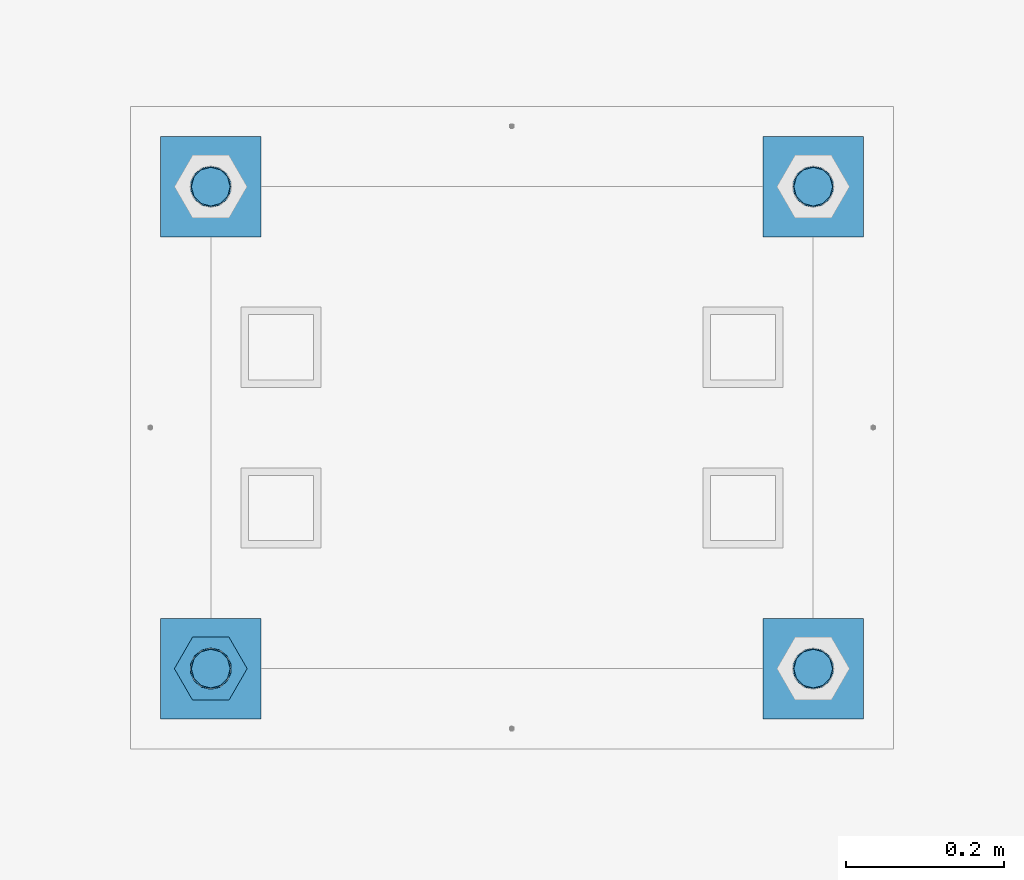
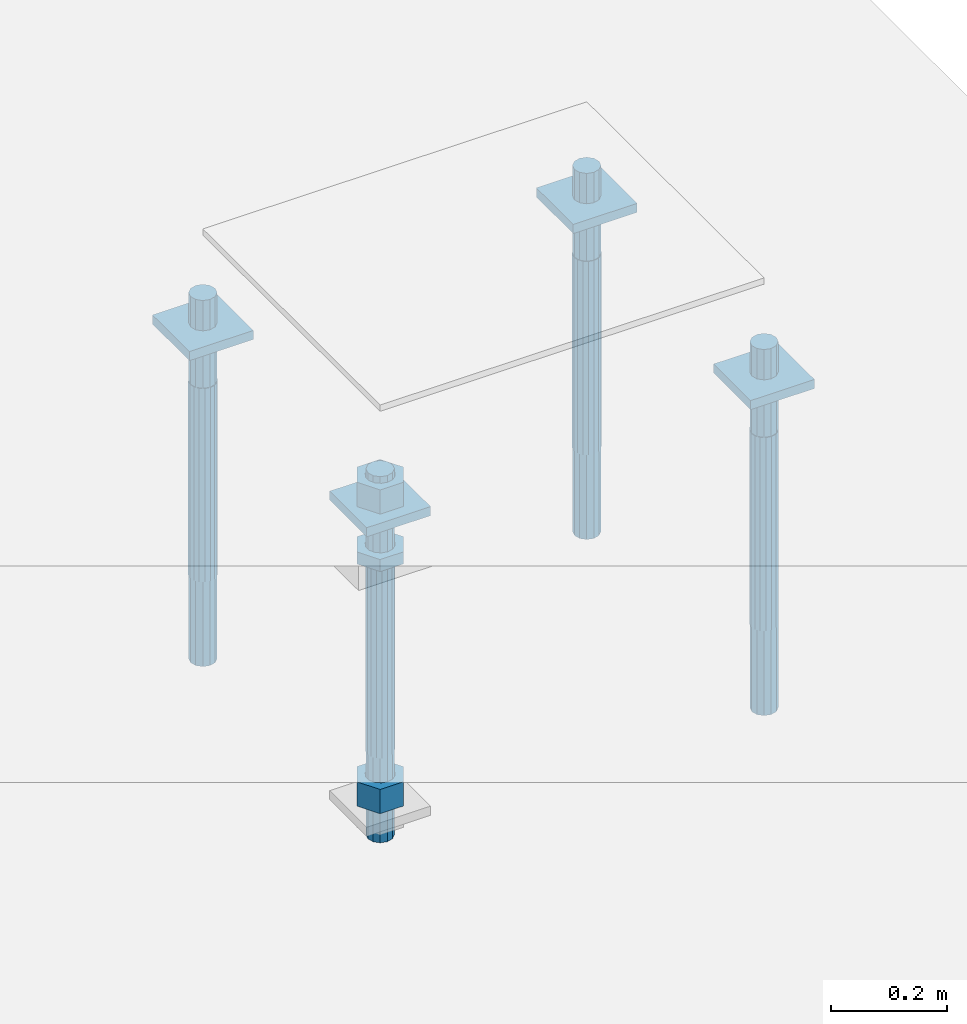
# One storey, part 2680 of 3843: 11 beams, 1 element without a shape of its own.
"""IFC2X3 building model written with IfcOpenShell, lengths in millimetres."""

from ifc_helpers import new_model, si_unit, frame, origin_with_axes, place, context, subcontext, project, spatial, faceted_brep, material, type_object, element, aggregate, save


model = new_model("IFC2X3")

# Units and contexts
model_context = context("Model", 3, precision=1e-05, world=origin_with_axes())
body_context = subcontext(model_context, "Body", "Model", "MODEL_VIEW")
ifc_project = project(units=[si_unit("LENGTHUNIT", "METRE", prefix="MILLI"), si_unit("AREAUNIT", "SQUARE_METRE"), si_unit("VOLUMEUNIT", "CUBIC_METRE"), si_unit("MASSUNIT", "GRAM", prefix="KILO"), si_unit("TIMEUNIT", "SECOND"), si_unit("PLANEANGLEUNIT", "RADIAN"), si_unit("SOLIDANGLEUNIT", "STERADIAN"), si_unit("THERMODYNAMICTEMPERATUREUNIT", "DEGREE_CELSIUS"), si_unit("LUMINOUSINTENSITYUNIT", "LUMEN")], contexts=[model_context])

# Site, building, storey
site_placement = place(None, origin_with_axes())
site = spatial("IfcSite", under=ifc_project, at=site_placement, CompositionType="ELEMENT")
building_placement = place(site_placement, origin_with_axes())
building = spatial("IfcBuilding", under=site, at=building_placement, Name="Undefined", CompositionType="ELEMENT")
storey_placement = place(building_placement, origin_with_axes())
storey = spatial("IfcBuildingStorey", under=building, at=storey_placement, Name="Undefined", CompositionType="ELEMENT", Elevation=0.0)

# Assembly, beams
assembly_placement = place(storey_placement, origin_with_axes())
assembly = element("IfcElementAssembly", 1, at=assembly_placement, inside=storey, Name="TEMPLATE", AssemblyPlace="NOTDEFINED", PredefinedType="RIGID_FRAME")
ifc_material_1 = material(Name="STEEL/A572-50")
beam_type_1 = type_object("IfcBeamType", PredefinedType="NOTDEFINED")
beam_1_placement = place(assembly_placement, frame((118465.6, 29044.9000015259, 29873.575), z_axis=(1.0, 0.0, 0.0), x_axis=(0.0, 1.0, 0.0)))
beam_1 = element("IfcBeam", 2, at=beam_1_placement, type_object=beam_type_1, material=ifc_material_1, Name="WASHER_PLATE", context=body_context, shape_type="Brep", body=[
    faceted_brep([(0.0, 9.52500000000146, -63.5), (0.0, 9.52500000000146, 63.5), (127.0, 9.52500000000146, 63.5), (127.0, 9.52500000000146, -63.5), (0.0, -9.52500000000146, 63.5), (127.0, -9.52500000000146, 63.5), (0.0, -9.52500000000146, -63.5), (127.0, -9.52500000000146, -63.5)], [[[0, 1, 2, 3]], [[1, 4, 5, 2]], [[4, 6, 7, 5]], [[6, 0, 3, 7]], [[5, 7, 3, 2]], [[6, 4, 1, 0]]]),
])
beam_2_placement = place(assembly_placement, frame((119227.6, 29044.9000015259, 29873.575), z_axis=(1.0, 0.0, 0.0), x_axis=(0.0, 1.0, 0.0)))
beam_2 = element("IfcBeam", 3, at=beam_2_placement, type_object=beam_type_1, material=ifc_material_1, Name="WASHER_PLATE", context=body_context, shape_type="Brep", body=[
    faceted_brep([(0.0, 9.52500000000146, -63.5), (0.0, 9.52500000000146, 63.5), (127.0, 9.52500000000146, 63.5), (127.0, 9.52500000000146, -63.5), (0.0, -9.52500000000146, 63.5), (127.0, -9.52500000000146, 63.5), (0.0, -9.52500000000146, -63.5), (127.0, -9.52500000000146, -63.5)], [[[0, 1, 2, 3]], [[1, 4, 5, 2]], [[4, 6, 7, 5]], [[6, 0, 3, 7]], [[5, 7, 3, 2]], [[6, 4, 1, 0]]]),
])
beam_3_placement = place(assembly_placement, frame((118465.6, 29654.5000015259, 29873.575), z_axis=(1.0, 0.0, 0.0), x_axis=(0.0, 1.0, 0.0)))
beam_3 = element("IfcBeam", 4, at=beam_3_placement, type_object=beam_type_1, material=ifc_material_1, Name="WASHER_PLATE", context=body_context, shape_type="Brep", body=[
    faceted_brep([(0.0, 9.52500000000146, -63.5), (0.0, 9.52500000000146, 63.5), (127.0, 9.52500000000146, 63.5), (127.0, 9.52500000000146, -63.5), (0.0, -9.52500000000146, 63.5), (127.0, -9.52500000000146, 63.5), (0.0, -9.52500000000146, -63.5), (127.0, -9.52500000000146, -63.5)], [[[0, 1, 2, 3]], [[1, 4, 5, 2]], [[4, 6, 7, 5]], [[6, 0, 3, 7]], [[5, 7, 3, 2]], [[6, 4, 1, 0]]]),
])
beam_4_placement = place(assembly_placement, frame((119227.6, 29654.5000015259, 29873.575), z_axis=(1.0, 0.0, 0.0), x_axis=(0.0, 1.0, 0.0)))
beam_4 = element("IfcBeam", 5, at=beam_4_placement, type_object=beam_type_1, material=ifc_material_1, Name="WASHER_PLATE", context=body_context, shape_type="Brep", body=[
    faceted_brep([(0.0, 9.52500000000146, -63.5), (0.0, 9.52500000000146, 63.5), (127.0, 9.52500000000146, 63.5), (127.0, 9.52500000000146, -63.5), (0.0, -9.52500000000146, 63.5), (127.0, -9.52500000000146, 63.5), (0.0, -9.52500000000146, -63.5), (127.0, -9.52500000000146, -63.5)], [[[0, 1, 2, 3]], [[1, 4, 5, 2]], [[4, 6, 7, 5]], [[6, 0, 3, 7]], [[5, 7, 3, 2]], [[6, 4, 1, 0]]]),
])
ifc_material_2 = material(Name="STEEL/A36")
beam_type_2 = type_object("IfcBeamType", Name="2_HALF_NUT", PredefinedType="NOTDEFINED")
beam_5_placement = place(assembly_placement, frame((118465.6, 29108.4000015259, 29787.85), z_axis=(0.0, 1.0, 0.0), x_axis=(0.0, 0.0, -1.0)))
beam_5 = element("IfcBeam", 6, at=beam_5_placement, type_object=beam_type_2, material=ifc_material_2, Name="NUT", ObjectType="2_HALF_NUT", context=body_context, shape_type="Brep", body=[
    faceted_brep([(0.0, -46.0369987487793, 0.0), (0.0, -23.0184993743896, -39.869213104248), (25.4000000000015, -23.0184993743896, -39.869213104248), (25.4000000000015, -46.0369987487793, 0.0), (0.0, 23.0184993743896, -39.869213104248), (25.4000000000015, 23.0184993743896, -39.869213104248), (0.0, 46.0369987487793, 0.0), (25.4000000000015, 46.0369987487793, 0.0), (0.0, 23.0184993743896, 39.869213104248), (25.4000000000015, 23.0184993743896, 39.869213104248), (0.0, -23.0184993743896, 39.869213104248), (25.4000000000015, -23.0184993743896, 39.869213104248), (0.0, 0.0, 26.1940002441406), (0.0, 11.3650617044477, 23.5999013092805), (25.4000000000015, 11.3650617044477, 23.5999013092805), (25.4000000000015, 0.0, 26.1940002441406), (0.0, 20.4791109456419, 16.3316083006721), (25.4000000000015, 20.4791109456419, 16.3316083006721), (0.0, 25.5370200498292, 5.82867859874386), (25.4000000000015, 25.5370200498292, 5.82867859874386), (0.0, 25.5370200498292, -5.82867859874386), (25.4000000000015, 25.5370200498292, -5.82867859874386), (0.0, 20.4791109456419, -16.3316083006721), (25.4000000000015, 20.4791109456419, -16.3316083006721), (0.0, 11.3650617044477, -23.5999013092805), (25.4000000000015, 11.3650617044477, -23.5999013092805), (0.0, 0.0, -26.1940002441406), (25.4000000000015, 0.0, -26.1940002441406), (0.0, -11.3650617044477, -23.5999013092805), (25.4000000000015, -11.3650617044477, -23.5999013092805), (0.0, -20.4791109456419, -16.3316083006721), (25.4000000000015, -20.4791109456419, -16.3316083006721), (0.0, -25.5370200498292, -5.82867859874386), (25.4000000000015, -25.5370200498292, -5.82867859874386), (0.0, -25.5370200498292, 5.82867859874386), (25.4000000000015, -25.5370200498292, 5.82867859874386), (0.0, -20.4791109456419, 16.3316083006721), (25.4000000000015, -20.4791109456419, 16.3316083006721), (0.0, -11.3650617044477, 23.5999013092805), (25.4000000000015, -11.3650617044477, 23.5999013092805)], [[[0, 1, 2, 3]], [[1, 4, 5, 2]], [[4, 6, 7, 5]], [[6, 8, 9, 7]], [[8, 10, 11, 9]], [[10, 0, 3, 11]], [[12, 13, 14, 15]], [[13, 16, 17, 14]], [[16, 18, 19, 17]], [[18, 20, 21, 19]], [[20, 22, 23, 21]], [[22, 24, 25, 23]], [[24, 26, 27, 25]], [[26, 28, 29, 27]], [[28, 30, 31, 29]], [[30, 32, 33, 31]], [[32, 34, 35, 33]], [[34, 36, 37, 35]], [[36, 38, 39, 37]], [[38, 12, 15, 39]], [[5, 7, 9, 11, 3, 2], [17, 19, 21, 23, 25, 27, 29, 31, 33, 35, 37, 39, 15, 14]], [[10, 8, 6, 4, 1, 0], [38, 36, 34, 32, 30, 28, 26, 24, 22, 20, 18, 16, 13, 12]]]),
])
beam_type_3 = type_object("IfcBeamType", Name="2_HEAVY_HEX_NUT", PredefinedType="NOTDEFINED")
beam_6_placement = place(assembly_placement, frame((118465.6, 29108.4000015259, 29933.9), z_axis=(0.0, 1.0, 0.0), x_axis=(0.0, 0.0, -1.0)))
beam_6 = element("IfcBeam", 7, at=beam_6_placement, type_object=beam_type_3, material=ifc_material_2, Name="NUT", ObjectType="2_HEAVY_HEX_NUT", context=body_context, shape_type="Brep", body=[
    faceted_brep([(0.0, -46.0369987487793, 0.0), (0.0, -23.0184993743896, -39.869213104248), (50.7999999999993, -23.0184993743896, -39.869213104248), (50.7999999999993, -46.0369987487793, 0.0), (0.0, 23.0184993743896, -39.869213104248), (50.7999999999993, 23.0184993743896, -39.869213104248), (0.0, 46.0369987487793, 0.0), (50.7999999999993, 46.0369987487793, 0.0), (0.0, 23.0184993743896, 39.869213104248), (50.7999999999993, 23.0184993743896, 39.869213104248), (0.0, -23.0184993743896, 39.869213104248), (50.7999999999993, -23.0184993743896, 39.869213104248), (0.0, 0.0, 26.1940002441406), (0.0, 11.3650617044477, 23.5999013092805), (50.7999999999993, 11.3650617044477, 23.5999013092805), (50.7999999999993, 0.0, 26.1940002441406), (0.0, 20.4791109456419, 16.3316083006721), (50.7999999999993, 20.4791109456419, 16.3316083006721), (0.0, 25.5370200498292, 5.82867859874386), (50.7999999999993, 25.5370200498292, 5.82867859874386), (0.0, 25.5370200498292, -5.82867859874386), (50.7999999999993, 25.5370200498292, -5.82867859874386), (0.0, 20.4791109456419, -16.3316083006721), (50.7999999999993, 20.4791109456419, -16.3316083006721), (0.0, 11.3650617044477, -23.5999013092805), (50.7999999999993, 11.3650617044477, -23.5999013092805), (0.0, 0.0, -26.1940002441406), (50.7999999999993, 0.0, -26.1940002441406), (0.0, -11.3650617044477, -23.5999013092805), (50.7999999999993, -11.3650617044477, -23.5999013092805), (0.0, -20.4791109456419, -16.3316083006721), (50.7999999999993, -20.4791109456419, -16.3316083006721), (0.0, -25.5370200498292, -5.82867859874386), (50.7999999999993, -25.5370200498292, -5.82867859874386), (0.0, -25.5370200498292, 5.82867859874386), (50.7999999999993, -25.5370200498292, 5.82867859874386), (0.0, -20.4791109456419, 16.3316083006721), (50.7999999999993, -20.4791109456419, 16.3316083006721), (0.0, -11.3650617044477, 23.5999013092805), (50.7999999999993, -11.3650617044477, 23.5999013092805)], [[[0, 1, 2, 3]], [[1, 4, 5, 2]], [[4, 6, 7, 5]], [[6, 8, 9, 7]], [[8, 10, 11, 9]], [[10, 0, 3, 11]], [[12, 13, 14, 15]], [[13, 16, 17, 14]], [[16, 18, 19, 17]], [[18, 20, 21, 19]], [[20, 22, 23, 21]], [[22, 24, 25, 23]], [[24, 26, 27, 25]], [[26, 28, 29, 27]], [[28, 30, 31, 29]], [[30, 32, 33, 31]], [[32, 34, 35, 33]], [[34, 36, 37, 35]], [[36, 38, 39, 37]], [[38, 12, 15, 39]], [[5, 7, 9, 11, 3, 2], [17, 19, 21, 23, 25, 27, 29, 31, 33, 35, 37, 39, 15, 14]], [[10, 8, 6, 4, 1, 0], [38, 36, 34, 32, 30, 28, 26, 24, 22, 20, 18, 16, 13, 12]]]),
])
beam_7_placement = place(assembly_placement, frame((118465.6, 29108.4000015259, 29305.25), z_axis=(0.0, 1.0, 0.0), x_axis=(0.0, 0.0, -1.0)))
beam_7 = element("IfcBeam", 8, at=beam_7_placement, type_object=beam_type_3, material=ifc_material_2, Name="NUT", ObjectType="2_HEAVY_HEX_NUT", context=body_context, shape_type="Brep", body=[
    faceted_brep([(0.0, -46.0369987487793, 0.0), (0.0, -23.0184993743896, -39.869213104248), (50.7999999999993, -23.0184993743896, -39.869213104248), (50.7999999999993, -46.0369987487793, 0.0), (0.0, 23.0184993743896, -39.869213104248), (50.7999999999993, 23.0184993743896, -39.869213104248), (0.0, 46.0369987487793, 0.0), (50.7999999999993, 46.0369987487793, 0.0), (0.0, 23.0184993743896, 39.869213104248), (50.7999999999993, 23.0184993743896, 39.869213104248), (0.0, -23.0184993743896, 39.869213104248), (50.7999999999993, -23.0184993743896, 39.869213104248), (0.0, 0.0, 26.1940002441406), (0.0, 11.3650617044477, 23.5999013092805), (50.7999999999993, 11.3650617044477, 23.5999013092805), (50.7999999999993, 0.0, 26.1940002441406), (0.0, 20.4791109456419, 16.3316083006721), (50.7999999999993, 20.4791109456419, 16.3316083006721), (0.0, 25.5370200498292, 5.82867859874386), (50.7999999999993, 25.5370200498292, 5.82867859874386), (0.0, 25.5370200498292, -5.82867859874386), (50.7999999999993, 25.5370200498292, -5.82867859874386), (0.0, 20.4791109456419, -16.3316083006721), (50.7999999999993, 20.4791109456419, -16.3316083006721), (0.0, 11.3650617044477, -23.5999013092805), (50.7999999999993, 11.3650617044477, -23.5999013092805), (0.0, 0.0, -26.1940002441406), (50.7999999999993, 0.0, -26.1940002441406), (0.0, -11.3650617044477, -23.5999013092805), (50.7999999999993, -11.3650617044477, -23.5999013092805), (0.0, -20.4791109456419, -16.3316083006721), (50.7999999999993, -20.4791109456419, -16.3316083006721), (0.0, -25.5370200498292, -5.82867859874386), (50.7999999999993, -25.5370200498292, -5.82867859874386), (0.0, -25.5370200498292, 5.82867859874386), (50.7999999999993, -25.5370200498292, 5.82867859874386), (0.0, -20.4791109456419, 16.3316083006721), (50.7999999999993, -20.4791109456419, 16.3316083006721), (0.0, -11.3650617044477, 23.5999013092805), (50.7999999999993, -11.3650617044477, 23.5999013092805)], [[[0, 1, 2, 3]], [[1, 4, 5, 2]], [[4, 6, 7, 5]], [[6, 8, 9, 7]], [[8, 10, 11, 9]], [[10, 0, 3, 11]], [[12, 13, 14, 15]], [[13, 16, 17, 14]], [[16, 18, 19, 17]], [[18, 20, 21, 19]], [[20, 22, 23, 21]], [[22, 24, 25, 23]], [[24, 26, 27, 25]], [[26, 28, 29, 27]], [[28, 30, 31, 29]], [[30, 32, 33, 31]], [[32, 34, 35, 33]], [[34, 36, 37, 35]], [[36, 38, 39, 37]], [[38, 12, 15, 39]], [[5, 7, 9, 11, 3, 2], [17, 19, 21, 23, 25, 27, 29, 31, 33, 35, 37, 39, 15, 14]], [[10, 8, 6, 4, 1, 0], [38, 36, 34, 32, 30, 28, 26, 24, 22, 20, 18, 16, 13, 12]]]),
])
ifc_material_3 = material()
beam_type_4 = type_object("IfcBeamType", PredefinedType="NOTDEFINED")
beam_8_placement = place(assembly_placement, frame((118465.600001526, 29718.0, 29762.45), z_axis=(1.0, 0.0, 0.0), x_axis=(0.0, 0.0, -1.0)))
beam_8 = element("IfcBeam", 9, at=beam_8_placement, type_object=beam_type_4, material=ifc_material_3, Name="ANCHOR_ROD", context=body_context, shape_type="Brep", body=[
    faceted_brep([(0.0, -23.4665401257807, -9.72015918207035), (0.0, -17.9605122421344, -17.9605122421417), (406.399999999998, -17.9605122421344, -17.9605122421417), (406.399999999998, -23.4665401257807, -9.72015918207035), (0.0, -9.72015918207762, -23.466540125788), (406.399999999998, -9.72015918207762, -23.466540125788), (0.0, 0.0, -25.4000000000015), (406.399999999998, 0.0, -25.4000000000015), (0.0, 9.72015918207762, -23.466540125788), (406.399999999998, 9.72015918207762, -23.466540125788), (0.0, 17.9605122421344, -17.9605122421417), (406.399999999998, 17.9605122421344, -17.9605122421417), (0.0, 23.4665401257807, -9.72015918207035), (406.399999999998, 23.4665401257807, -9.72015918207035), (0.0, 25.3999996185303, 0.0), (406.399999999998, 25.3999999999942, 0.0), (0.0, 23.4665401257807, 9.72015918207035), (406.399999999998, 23.4665401257807, 9.72015918207035), (0.0, 17.9605122421344, 17.9605122421417), (406.399999999998, 17.9605122421344, 17.9605122421417), (0.0, 9.72015918207762, 23.466540125788), (406.399999999998, 9.72015918207762, 23.466540125788), (0.0, 0.0, 25.4000000000015), (406.399999999998, 0.0, 25.4000000000015), (0.0, -9.72015918207762, 23.466540125788), (406.399999999998, -9.72015918207762, 23.466540125788), (0.0, -17.9605122421344, 17.9605122421417), (406.399999999998, -17.9605122421344, 17.9605122421417), (0.0, -23.4665401257807, 9.72015918207035), (406.399999999998, -23.4665401257807, 9.72015918207035), (0.0, -25.3999996185303, 0.0), (406.399999999998, -25.3999999999942, 0.0), (584.200000000001, -12.2499999999854, -21.2176223927163), (584.200000000001, 1.45519152283669e-11, -24.5), (584.200000000001, 12.2500000000146, -21.2176223927163), (584.200000000001, 21.2176223927381, -12.25), (584.200000000001, 24.5000000000146, 0.0), (584.200000000001, 21.2176223927381, 12.25), (584.200000000001, 12.2500000000146, 21.2176223927163), (584.200000000001, 1.45519152283669e-11, 24.5), (584.200000000001, -12.2499999999854, 21.2176223927163), (584.200000000001, -21.217622392709, 12.25), (584.200000000001, -24.4999999999854, 0.0), (584.200000000001, -21.217622392709, -12.25), (406.399999999998, -24.4999999999854, 0.0), (406.399999999998, -21.217622392709, -12.25), (406.399999999998, -12.2499999999854, -21.2176223927163), (406.399999999998, 1.45519152283669e-11, -24.5), (406.399999999998, 12.2500000000146, -21.2176223927163), (406.399999999998, 21.2176223927381, -12.25), (406.399999999998, 24.5000000000146, 0.0), (406.399999999998, 21.2176223927381, 12.25), (406.399999999998, 12.2500000000146, 21.2176223927163), (406.399999999998, 1.45519152283669e-11, 24.5), (406.399999999998, -12.2499999999854, 21.2176223927163), (406.399999999998, -21.217622392709, 12.25), (0.0, 12.2500000000146, 21.2176223927163), (0.0, 1.45519152283669e-11, 24.5), (0.0, -12.2499999999854, 21.2176223927163), (0.0, -21.217622392709, 12.25), (0.0, -24.4999999999854, 0.0), (0.0, -21.217622392709, -12.25), (0.0, -12.2499999999854, -21.2176223927163), (0.0, 1.45519152283669e-11, -24.5), (0.0, 12.2500000000146, -21.2176223927163), (0.0, 21.2176223927381, -12.25), (0.0, 24.5000000000146, 0.0), (0.0, 21.2176223927381, 12.25), (-184.150000000001, -21.217622392709, 12.25), (-184.150000000001, -12.2499999999854, 21.2176223927163), (-184.150000000001, 1.45519152283669e-11, 24.5), (-184.150000000001, 12.2500000000146, 21.2176223927163), (-184.150000000001, 21.2176223927381, 12.25), (-184.150000000001, 24.5000000000146, 0.0), (-184.150000000001, 21.2176223927381, -12.25), (-184.150000000001, 12.2500000000146, -21.2176223927163), (-184.150000000001, 1.45519152283669e-11, -24.5), (-184.150000000001, -12.2499999999854, -21.2176223927163), (-184.150000000001, -21.217622392709, -12.25), (-184.150000000001, -24.4999999999854, 0.0)], [[[0, 1, 2, 3]], [[1, 4, 5, 2]], [[4, 6, 7, 5]], [[6, 8, 9, 7]], [[8, 10, 11, 9]], [[10, 12, 13, 11]], [[12, 14, 15, 13]], [[14, 16, 17, 15]], [[16, 18, 19, 17]], [[18, 20, 21, 19]], [[20, 22, 23, 21]], [[22, 24, 25, 23]], [[24, 26, 27, 25]], [[26, 28, 29, 27]], [[28, 30, 31, 29]], [[32, 33, 34, 35, 36, 37, 38, 39, 40, 41, 42, 43]], [[43, 42, 44, 45]], [[32, 43, 45, 46]], [[33, 32, 46, 47]], [[34, 33, 47, 48]], [[35, 34, 48, 49]], [[36, 35, 49, 50]], [[37, 36, 50, 51]], [[38, 37, 51, 52]], [[39, 38, 52, 53]], [[40, 39, 53, 54]], [[41, 40, 54, 55]], [[42, 41, 55, 44]], [[2, 5, 7, 9, 11, 13, 15, 17, 19, 21, 23, 25, 27, 29, 31, 3], [54, 53, 52, 51, 50, 49, 48, 47, 46, 45, 44, 55]], [[30, 0, 3, 31]], [[28, 26, 24, 22, 20, 18, 16, 14, 12, 10, 8, 6, 4, 1, 0, 30], [56, 57, 58, 59, 60, 61, 62, 63, 64, 65, 66, 67]], [[68, 69, 70, 71, 72, 73, 74, 75, 76, 77, 78, 79]], [[71, 70, 57, 56]], [[72, 71, 56, 67]], [[73, 72, 67, 66]], [[74, 73, 66, 65]], [[75, 74, 65, 64]], [[76, 75, 64, 63]], [[77, 76, 63, 62]], [[78, 77, 62, 61]], [[79, 78, 61, 60]], [[68, 79, 60, 59]], [[69, 68, 59, 58]], [[70, 69, 58, 57]]]),
])
beam_9_placement = place(assembly_placement, frame((119227.600001526, 29718.0, 29762.45), z_axis=(1.0, 0.0, 0.0), x_axis=(0.0, 0.0, -1.0)))
beam_9 = element("IfcBeam", 10, at=beam_9_placement, type_object=beam_type_4, material=ifc_material_3, Name="ANCHOR_ROD", context=body_context, shape_type="Brep", body=[
    faceted_brep([(0.0, -23.4665401257807, -9.72015918207035), (0.0, -17.9605122421344, -17.9605122421417), (406.399999999998, -17.9605122421344, -17.9605122421417), (406.399999999998, -23.4665401257807, -9.72015918207035), (0.0, -9.72015918207762, -23.466540125788), (406.399999999998, -9.72015918207762, -23.466540125788), (0.0, 0.0, -25.4000000000015), (406.399999999998, 0.0, -25.4000000000015), (0.0, 9.72015918207762, -23.466540125788), (406.399999999998, 9.72015918207762, -23.466540125788), (0.0, 17.9605122421344, -17.9605122421417), (406.399999999998, 17.9605122421344, -17.9605122421417), (0.0, 23.4665401257807, -9.72015918207035), (406.399999999998, 23.4665401257807, -9.72015918207035), (0.0, 25.3999996185303, 0.0), (406.399999999998, 25.3999999999942, 0.0), (0.0, 23.4665401257807, 9.72015918207035), (406.399999999998, 23.4665401257807, 9.72015918207035), (0.0, 17.9605122421344, 17.9605122421417), (406.399999999998, 17.9605122421344, 17.9605122421417), (0.0, 9.72015918207762, 23.466540125788), (406.399999999998, 9.72015918207762, 23.466540125788), (0.0, 0.0, 25.4000000000015), (406.399999999998, 0.0, 25.4000000000015), (0.0, -9.72015918207762, 23.466540125788), (406.399999999998, -9.72015918207762, 23.466540125788), (0.0, -17.9605122421344, 17.9605122421417), (406.399999999998, -17.9605122421344, 17.9605122421417), (0.0, -23.4665401257807, 9.72015918207035), (406.399999999998, -23.4665401257807, 9.72015918207035), (0.0, -25.3999996185303, 0.0), (406.399999999998, -25.3999999999942, 0.0), (584.200000000001, -12.2499999999854, -21.2176223927163), (584.200000000001, 1.45519152283669e-11, -24.5), (584.200000000001, 12.2500000000146, -21.2176223927163), (584.200000000001, 21.2176223927381, -12.25), (584.200000000001, 24.5000000000146, 0.0), (584.200000000001, 21.2176223927381, 12.25), (584.200000000001, 12.2500000000146, 21.2176223927163), (584.200000000001, 1.45519152283669e-11, 24.5), (584.200000000001, -12.2499999999854, 21.2176223927163), (584.200000000001, -21.217622392709, 12.25), (584.200000000001, -24.4999999999854, 0.0), (584.200000000001, -21.217622392709, -12.25), (406.399999999998, -24.4999999999854, 0.0), (406.399999999998, -21.217622392709, -12.25), (406.399999999998, -12.2499999999854, -21.2176223927163), (406.399999999998, 1.45519152283669e-11, -24.5), (406.399999999998, 12.2500000000146, -21.2176223927163), (406.399999999998, 21.2176223927381, -12.25), (406.399999999998, 24.5000000000146, 0.0), (406.399999999998, 21.2176223927381, 12.25), (406.399999999998, 12.2500000000146, 21.2176223927163), (406.399999999998, 1.45519152283669e-11, 24.5), (406.399999999998, -12.2499999999854, 21.2176223927163), (406.399999999998, -21.217622392709, 12.25), (0.0, 12.2500000000146, 21.2176223927163), (0.0, 1.45519152283669e-11, 24.5), (0.0, -12.2499999999854, 21.2176223927163), (0.0, -21.217622392709, 12.25), (0.0, -24.4999999999854, 0.0), (0.0, -21.217622392709, -12.25), (0.0, -12.2499999999854, -21.2176223927163), (0.0, 1.45519152283669e-11, -24.5), (0.0, 12.2500000000146, -21.2176223927163), (0.0, 21.2176223927381, -12.25), (0.0, 24.5000000000146, 0.0), (0.0, 21.2176223927381, 12.25), (-184.150000000001, -21.217622392709, 12.25), (-184.150000000001, -12.2499999999854, 21.2176223927163), (-184.150000000001, 1.45519152283669e-11, 24.5), (-184.150000000001, 12.2500000000146, 21.2176223927163), (-184.150000000001, 21.2176223927381, 12.25), (-184.150000000001, 24.5000000000146, 0.0), (-184.150000000001, 21.2176223927381, -12.25), (-184.150000000001, 12.2500000000146, -21.2176223927163), (-184.150000000001, 1.45519152283669e-11, -24.5), (-184.150000000001, -12.2499999999854, -21.2176223927163), (-184.150000000001, -21.217622392709, -12.25), (-184.150000000001, -24.4999999999854, 0.0)], [[[0, 1, 2, 3]], [[1, 4, 5, 2]], [[4, 6, 7, 5]], [[6, 8, 9, 7]], [[8, 10, 11, 9]], [[10, 12, 13, 11]], [[12, 14, 15, 13]], [[14, 16, 17, 15]], [[16, 18, 19, 17]], [[18, 20, 21, 19]], [[20, 22, 23, 21]], [[22, 24, 25, 23]], [[24, 26, 27, 25]], [[26, 28, 29, 27]], [[28, 30, 31, 29]], [[32, 33, 34, 35, 36, 37, 38, 39, 40, 41, 42, 43]], [[43, 42, 44, 45]], [[32, 43, 45, 46]], [[33, 32, 46, 47]], [[34, 33, 47, 48]], [[35, 34, 48, 49]], [[36, 35, 49, 50]], [[37, 36, 50, 51]], [[38, 37, 51, 52]], [[39, 38, 52, 53]], [[40, 39, 53, 54]], [[41, 40, 54, 55]], [[42, 41, 55, 44]], [[2, 5, 7, 9, 11, 13, 15, 17, 19, 21, 23, 25, 27, 29, 31, 3], [54, 53, 52, 51, 50, 49, 48, 47, 46, 45, 44, 55]], [[30, 0, 3, 31]], [[28, 26, 24, 22, 20, 18, 16, 14, 12, 10, 8, 6, 4, 1, 0, 30], [56, 57, 58, 59, 60, 61, 62, 63, 64, 65, 66, 67]], [[68, 69, 70, 71, 72, 73, 74, 75, 76, 77, 78, 79]], [[71, 70, 57, 56]], [[72, 71, 56, 67]], [[73, 72, 67, 66]], [[74, 73, 66, 65]], [[75, 74, 65, 64]], [[76, 75, 64, 63]], [[77, 76, 63, 62]], [[78, 77, 62, 61]], [[79, 78, 61, 60]], [[68, 79, 60, 59]], [[69, 68, 59, 58]], [[70, 69, 58, 57]]]),
])
beam_10_placement = place(assembly_placement, frame((118465.600001526, 29108.4, 29762.45), z_axis=(1.0, 0.0, 0.0), x_axis=(0.0, 0.0, -1.0)))
beam_10 = element("IfcBeam", 11, at=beam_10_placement, type_object=beam_type_4, material=ifc_material_3, Name="ANCHOR_ROD", context=body_context, shape_type="Brep", body=[
    faceted_brep([(0.0, -23.4665401257807, -9.72015918207035), (0.0, -17.9605122421344, -17.9605122421417), (406.399999999998, -17.9605122421344, -17.9605122421417), (406.399999999998, -23.4665401257807, -9.72015918207035), (0.0, -9.72015918207762, -23.466540125788), (406.399999999998, -9.72015918207762, -23.466540125788), (0.0, 0.0, -25.4000000000015), (406.399999999998, 0.0, -25.4000000000015), (0.0, 9.72015918207762, -23.466540125788), (406.399999999998, 9.72015918207762, -23.466540125788), (0.0, 17.9605122421344, -17.9605122421417), (406.399999999998, 17.9605122421344, -17.9605122421417), (0.0, 23.4665401257807, -9.72015918207035), (406.399999999998, 23.4665401257807, -9.72015918207035), (0.0, 25.3999996185303, 0.0), (406.399999999998, 25.3999999999942, 0.0), (0.0, 23.4665401257807, 9.72015918207035), (406.399999999998, 23.4665401257807, 9.72015918207035), (0.0, 17.9605122421344, 17.9605122421417), (406.399999999998, 17.9605122421344, 17.9605122421417), (0.0, 9.72015918207762, 23.466540125788), (406.399999999998, 9.72015918207762, 23.466540125788), (0.0, 0.0, 25.4000000000015), (406.399999999998, 0.0, 25.4000000000015), (0.0, -9.72015918207762, 23.466540125788), (406.399999999998, -9.72015918207762, 23.466540125788), (0.0, -17.9605122421344, 17.9605122421417), (406.399999999998, -17.9605122421344, 17.9605122421417), (0.0, -23.4665401257807, 9.72015918207035), (406.399999999998, -23.4665401257807, 9.72015918207035), (0.0, -25.3999996185303, 0.0), (406.399999999998, -25.3999999999942, 0.0), (584.200000000001, -12.2499999999854, -21.2176223927163), (584.200000000001, 1.45519152283669e-11, -24.5), (584.200000000001, 12.2500000000146, -21.2176223927163), (584.200000000001, 21.2176223927381, -12.25), (584.200000000001, 24.5000000000146, 0.0), (584.200000000001, 21.2176223927381, 12.25), (584.200000000001, 12.2500000000146, 21.2176223927163), (584.200000000001, 1.45519152283669e-11, 24.5), (584.200000000001, -12.2499999999854, 21.2176223927163), (584.200000000001, -21.217622392709, 12.25), (584.200000000001, -24.4999999999854, 0.0), (584.200000000001, -21.217622392709, -12.25), (406.399999999998, -24.4999999999854, 0.0), (406.399999999998, -21.217622392709, -12.25), (406.399999999998, -12.2499999999854, -21.2176223927163), (406.399999999998, 1.45519152283669e-11, -24.5), (406.399999999998, 12.2500000000146, -21.2176223927163), (406.399999999998, 21.2176223927381, -12.25), (406.399999999998, 24.5000000000146, 0.0), (406.399999999998, 21.2176223927381, 12.25), (406.399999999998, 12.2500000000146, 21.2176223927163), (406.399999999998, 1.45519152283669e-11, 24.5), (406.399999999998, -12.2499999999854, 21.2176223927163), (406.399999999998, -21.217622392709, 12.25), (0.0, 12.2500000000146, 21.2176223927163), (0.0, 1.45519152283669e-11, 24.5), (0.0, -12.2499999999854, 21.2176223927163), (0.0, -21.217622392709, 12.25), (0.0, -24.4999999999854, 0.0), (0.0, -21.217622392709, -12.25), (0.0, -12.2499999999854, -21.2176223927163), (0.0, 1.45519152283669e-11, -24.5), (0.0, 12.2500000000146, -21.2176223927163), (0.0, 21.2176223927381, -12.25), (0.0, 24.5000000000146, 0.0), (0.0, 21.2176223927381, 12.25), (-184.150000000001, -21.217622392709, 12.25), (-184.150000000001, -12.2499999999854, 21.2176223927163), (-184.150000000001, 1.45519152283669e-11, 24.5), (-184.150000000001, 12.2500000000146, 21.2176223927163), (-184.150000000001, 21.2176223927381, 12.25), (-184.150000000001, 24.5000000000146, 0.0), (-184.150000000001, 21.2176223927381, -12.25), (-184.150000000001, 12.2500000000146, -21.2176223927163), (-184.150000000001, 1.45519152283669e-11, -24.5), (-184.150000000001, -12.2499999999854, -21.2176223927163), (-184.150000000001, -21.217622392709, -12.25), (-184.150000000001, -24.4999999999854, 0.0)], [[[0, 1, 2, 3]], [[1, 4, 5, 2]], [[4, 6, 7, 5]], [[6, 8, 9, 7]], [[8, 10, 11, 9]], [[10, 12, 13, 11]], [[12, 14, 15, 13]], [[14, 16, 17, 15]], [[16, 18, 19, 17]], [[18, 20, 21, 19]], [[20, 22, 23, 21]], [[22, 24, 25, 23]], [[24, 26, 27, 25]], [[26, 28, 29, 27]], [[28, 30, 31, 29]], [[32, 33, 34, 35, 36, 37, 38, 39, 40, 41, 42, 43]], [[43, 42, 44, 45]], [[32, 43, 45, 46]], [[33, 32, 46, 47]], [[34, 33, 47, 48]], [[35, 34, 48, 49]], [[36, 35, 49, 50]], [[37, 36, 50, 51]], [[38, 37, 51, 52]], [[39, 38, 52, 53]], [[40, 39, 53, 54]], [[41, 40, 54, 55]], [[42, 41, 55, 44]], [[2, 5, 7, 9, 11, 13, 15, 17, 19, 21, 23, 25, 27, 29, 31, 3], [54, 53, 52, 51, 50, 49, 48, 47, 46, 45, 44, 55]], [[30, 0, 3, 31]], [[28, 26, 24, 22, 20, 18, 16, 14, 12, 10, 8, 6, 4, 1, 0, 30], [56, 57, 58, 59, 60, 61, 62, 63, 64, 65, 66, 67]], [[68, 69, 70, 71, 72, 73, 74, 75, 76, 77, 78, 79]], [[71, 70, 57, 56]], [[72, 71, 56, 67]], [[73, 72, 67, 66]], [[74, 73, 66, 65]], [[75, 74, 65, 64]], [[76, 75, 64, 63]], [[77, 76, 63, 62]], [[78, 77, 62, 61]], [[79, 78, 61, 60]], [[68, 79, 60, 59]], [[69, 68, 59, 58]], [[70, 69, 58, 57]]]),
])
beam_11_placement = place(assembly_placement, frame((119227.600001526, 29108.4, 29762.45), z_axis=(1.0, 0.0, 0.0), x_axis=(0.0, 0.0, -1.0)))
beam_11 = element("IfcBeam", 12, at=beam_11_placement, type_object=beam_type_4, material=ifc_material_3, Name="ANCHOR_ROD", context=body_context, shape_type="Brep", body=[
    faceted_brep([(0.0, -23.4665401257807, -9.72015918207035), (0.0, -17.9605122421344, -17.9605122421417), (406.399999999998, -17.9605122421344, -17.9605122421417), (406.399999999998, -23.4665401257807, -9.72015918207035), (0.0, -9.72015918207762, -23.466540125788), (406.399999999998, -9.72015918207762, -23.466540125788), (0.0, 0.0, -25.4000000000015), (406.399999999998, 0.0, -25.4000000000015), (0.0, 9.72015918207762, -23.466540125788), (406.399999999998, 9.72015918207762, -23.466540125788), (0.0, 17.9605122421344, -17.9605122421417), (406.399999999998, 17.9605122421344, -17.9605122421417), (0.0, 23.4665401257807, -9.72015918207035), (406.399999999998, 23.4665401257807, -9.72015918207035), (0.0, 25.3999996185303, 0.0), (406.399999999998, 25.3999999999942, 0.0), (0.0, 23.4665401257807, 9.72015918207035), (406.399999999998, 23.4665401257807, 9.72015918207035), (0.0, 17.9605122421344, 17.9605122421417), (406.399999999998, 17.9605122421344, 17.9605122421417), (0.0, 9.72015918207762, 23.466540125788), (406.399999999998, 9.72015918207762, 23.466540125788), (0.0, 0.0, 25.4000000000015), (406.399999999998, 0.0, 25.4000000000015), (0.0, -9.72015918207762, 23.466540125788), (406.399999999998, -9.72015918207762, 23.466540125788), (0.0, -17.9605122421344, 17.9605122421417), (406.399999999998, -17.9605122421344, 17.9605122421417), (0.0, -23.4665401257807, 9.72015918207035), (406.399999999998, -23.4665401257807, 9.72015918207035), (0.0, -25.3999996185303, 0.0), (406.399999999998, -25.3999999999942, 0.0), (584.200000000001, -12.2499999999854, -21.2176223927163), (584.200000000001, 1.45519152283669e-11, -24.5), (584.200000000001, 12.2500000000146, -21.2176223927163), (584.200000000001, 21.2176223927381, -12.25), (584.200000000001, 24.5000000000146, 0.0), (584.200000000001, 21.2176223927381, 12.25), (584.200000000001, 12.2500000000146, 21.2176223927163), (584.200000000001, 1.45519152283669e-11, 24.5), (584.200000000001, -12.2499999999854, 21.2176223927163), (584.200000000001, -21.217622392709, 12.25), (584.200000000001, -24.4999999999854, 0.0), (584.200000000001, -21.217622392709, -12.25), (406.399999999998, -24.4999999999854, 0.0), (406.399999999998, -21.217622392709, -12.25), (406.399999999998, -12.2499999999854, -21.2176223927163), (406.399999999998, 1.45519152283669e-11, -24.5), (406.399999999998, 12.2500000000146, -21.2176223927163), (406.399999999998, 21.2176223927381, -12.25), (406.399999999998, 24.5000000000146, 0.0), (406.399999999998, 21.2176223927381, 12.25), (406.399999999998, 12.2500000000146, 21.2176223927163), (406.399999999998, 1.45519152283669e-11, 24.5), (406.399999999998, -12.2499999999854, 21.2176223927163), (406.399999999998, -21.217622392709, 12.25), (0.0, 12.2500000000146, 21.2176223927163), (0.0, 1.45519152283669e-11, 24.5), (0.0, -12.2499999999854, 21.2176223927163), (0.0, -21.217622392709, 12.25), (0.0, -24.4999999999854, 0.0), (0.0, -21.217622392709, -12.25), (0.0, -12.2499999999854, -21.2176223927163), (0.0, 1.45519152283669e-11, -24.5), (0.0, 12.2500000000146, -21.2176223927163), (0.0, 21.2176223927381, -12.25), (0.0, 24.5000000000146, 0.0), (0.0, 21.2176223927381, 12.25), (-184.150000000001, -21.217622392709, 12.25), (-184.150000000001, -12.2499999999854, 21.2176223927163), (-184.150000000001, 1.45519152283669e-11, 24.5), (-184.150000000001, 12.2500000000146, 21.2176223927163), (-184.150000000001, 21.2176223927381, 12.25), (-184.150000000001, 24.5000000000146, 0.0), (-184.150000000001, 21.2176223927381, -12.25), (-184.150000000001, 12.2500000000146, -21.2176223927163), (-184.150000000001, 1.45519152283669e-11, -24.5), (-184.150000000001, -12.2499999999854, -21.2176223927163), (-184.150000000001, -21.217622392709, -12.25), (-184.150000000001, -24.4999999999854, 0.0)], [[[0, 1, 2, 3]], [[1, 4, 5, 2]], [[4, 6, 7, 5]], [[6, 8, 9, 7]], [[8, 10, 11, 9]], [[10, 12, 13, 11]], [[12, 14, 15, 13]], [[14, 16, 17, 15]], [[16, 18, 19, 17]], [[18, 20, 21, 19]], [[20, 22, 23, 21]], [[22, 24, 25, 23]], [[24, 26, 27, 25]], [[26, 28, 29, 27]], [[28, 30, 31, 29]], [[32, 33, 34, 35, 36, 37, 38, 39, 40, 41, 42, 43]], [[43, 42, 44, 45]], [[32, 43, 45, 46]], [[33, 32, 46, 47]], [[34, 33, 47, 48]], [[35, 34, 48, 49]], [[36, 35, 49, 50]], [[37, 36, 50, 51]], [[38, 37, 51, 52]], [[39, 38, 52, 53]], [[40, 39, 53, 54]], [[41, 40, 54, 55]], [[42, 41, 55, 44]], [[2, 5, 7, 9, 11, 13, 15, 17, 19, 21, 23, 25, 27, 29, 31, 3], [54, 53, 52, 51, 50, 49, 48, 47, 46, 45, 44, 55]], [[30, 0, 3, 31]], [[28, 26, 24, 22, 20, 18, 16, 14, 12, 10, 8, 6, 4, 1, 0, 30], [56, 57, 58, 59, 60, 61, 62, 63, 64, 65, 66, 67]], [[68, 69, 70, 71, 72, 73, 74, 75, 76, 77, 78, 79]], [[71, 70, 57, 56]], [[72, 71, 56, 67]], [[73, 72, 67, 66]], [[74, 73, 66, 65]], [[75, 74, 65, 64]], [[76, 75, 64, 63]], [[77, 76, 63, 62]], [[78, 77, 62, 61]], [[79, 78, 61, 60]], [[68, 79, 60, 59]], [[69, 68, 59, 58]], [[70, 69, 58, 57]]]),
])
aggregate(assembly, [beam_8, beam_9, beam_10, beam_11, beam_1, beam_2, beam_3, beam_4, beam_5, beam_6, beam_7])

save(model, "model.ifc")
